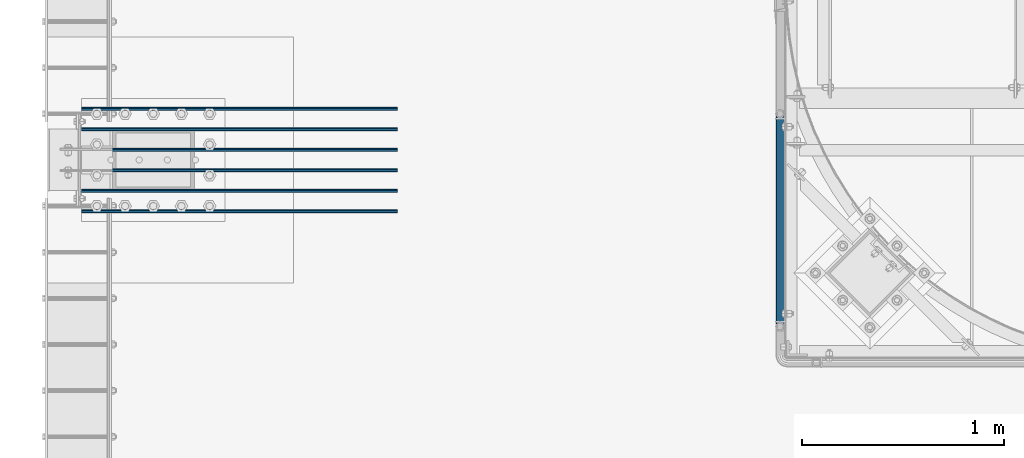
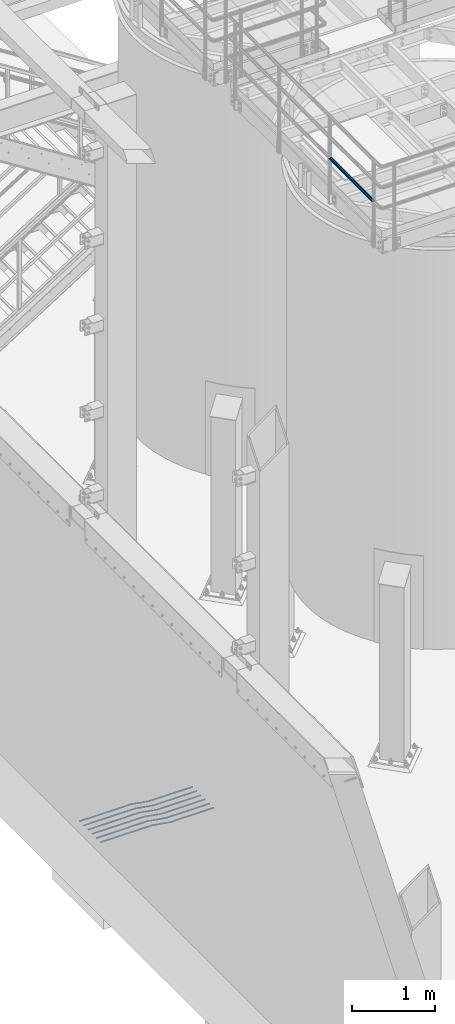
# One storey, part 913 of 1876: 7 beams, 2 elements without a shape of their own.
"""IFC2X3 building model written with IfcOpenShell, lengths in millimetres."""

from ifc_helpers import new_model, si_unit, frame, origin_with_axes, place, context, subcontext, project, spatial, faceted_brep, material, type_object, element, aggregate, save


model = new_model("IFC2X3")

# Units and contexts
model_context = context("Model", 3, precision=1e-05, world=origin_with_axes())
body_context = subcontext(model_context, "Body", "Model", "MODEL_VIEW")
ifc_project = project(units=[si_unit("LENGTHUNIT", "METRE", prefix="MILLI"), si_unit("AREAUNIT", "SQUARE_METRE"), si_unit("VOLUMEUNIT", "CUBIC_METRE"), si_unit("MASSUNIT", "GRAM", prefix="KILO"), si_unit("TIMEUNIT", "SECOND"), si_unit("PLANEANGLEUNIT", "RADIAN"), si_unit("SOLIDANGLEUNIT", "STERADIAN"), si_unit("THERMODYNAMICTEMPERATUREUNIT", "DEGREE_CELSIUS"), si_unit("LUMINOUSINTENSITYUNIT", "LUMEN")], contexts=[model_context])

# Site, building, storey
site_placement = place(None, origin_with_axes())
site = spatial("IfcSite", under=ifc_project, at=site_placement, CompositionType="ELEMENT")
building_placement = place(site_placement, origin_with_axes())
building = spatial("IfcBuilding", under=site, at=building_placement, Name="Undefined", CompositionType="ELEMENT")
storey_placement = place(building_placement, origin_with_axes())
storey = spatial("IfcBuildingStorey", under=building, at=storey_placement, Name="Undefined", CompositionType="ELEMENT", Elevation=0.0)

# Assembly, beam
assembly_1_placement = place(storey_placement, origin_with_axes())
assembly_1 = element("IfcElementAssembly", 1, at=assembly_1_placement, inside=storey, Name="HANDRAIL", AssemblyPlace="NOTDEFINED", PredefinedType="RIGID_FRAME")
ifc_material_1 = material()
beam_type_1 = type_object("IfcBeamType", Name="PIPE1-1/4STD", PredefinedType="NOTDEFINED")
beam_1_placement = place(assembly_1_placement, frame((3338.06943150122, -15252.6644042969, 8480.425), z_axis=(0.0, 0.0, 1.0), x_axis=(0.0, 1.0, 0.0)))
beam_1 = element("IfcBeam", 2, at=beam_1_placement, type_object=beam_type_1, material=ifc_material_1, Name="RAIL", ObjectType="PIPE1-1/4STD", context=body_context, shape_type="Brep", body=[
    faceted_brep([(1035.84245243742, -10.5409999999993, 18.2575475625836), (1035.84245243742, -10.5409999999993, 13.3999612267253), (1035.36603877327, -8.76300000000083, 15.1779612267255), (1033.018, 0.0, 17.5259999999998), (1033.018, 0.0, 21.0820000000003), (1035.36603877327, 8.76300000000083, 15.1779612267255), (1035.84245243742, 10.5409999999993, 13.3999612267253), (1035.84245243742, 10.5409999999993, 18.2575475625836), (1054.1, 21.0820000000003, 0.0), (1043.559, 18.2575475625836, 10.5409999999993), (1043.559, 18.2575475625836, -10.5409999999993), (1040.47941366414, 15.1779612267255, 8.76300000000083), (1042.82745243742, 17.5259999999998, 0.0), (1040.47941366414, 15.1779612267255, -8.76300000000083), (1035.84245243742, 10.5409999999993, -13.3999612267253), (1035.84245243742, 10.5409999999993, -18.2575475625836), (1035.36603877327, 8.76300000000083, -15.1779612267255), (1033.018, 0.0, -17.5259999999998), (1033.018, 0.0, -21.0820000000003), (1035.84245243742, -10.5409999999993, -13.3999612267253), (1035.84245243742, -10.5409999999993, -18.2575475625836), (1035.36603877327, -8.76300000000083, -15.1779612267255), (1054.1, -21.0820000000003, 0.0), (1043.559, -18.2575475625836, -10.5409999999993), (1043.559, -18.2575475625836, 10.5409999999993), (1040.47941366414, -15.1779612267255, -8.76300000000083), (1042.82745243742, -17.5259999999998, 0.0), (1040.47941366414, -15.1779612267255, 8.76300000000083), (10.5409999957128, -18.2575475672238, -10.5409999999993), (18.2575475625817, -10.5410000000011, -18.2575475625836), (9.09494701772928e-13, 21.0820000000003, 0.0), (10.5409999957128, 18.2575475579433, -10.5409999999993), (10.5409999999983, 18.2575475625836, 10.5410000000011), (18.2575475625817, 10.5409999999993, 18.2575475625836), (21.0819999999985, 1.81898940354586e-12, 21.0820000000003), (18.2575475625817, 10.5409999999993, -18.2575475625836), (21.0819999999985, 0.0, -21.0819999999985), (21.0819999999985, 0.0, -17.5259999999998), (18.2575475625817, -10.5409999999974, -13.3999612267271), (18.7339612267233, -8.76300000000083, -15.1779612267255), (18.7339612267251, 8.76299999999901, -15.1779612267255), (18.2575475625817, 10.5410000000011, -13.3999612267235), (13.6205863358573, 15.1779612267255, -8.76299999999901), (11.2725475625839, 17.5259999999998, 0.0), (13.6205863358573, 15.1779612267255, 8.76300000000083), (18.2575475625817, 10.5410000000011, 13.3999612267253), (18.7339612267251, 8.76299999999901, 15.1779612267273), (21.0819999999985, 1.81898940354586e-12, 17.5259999999998), (18.7339612267233, -8.76300000000083, 15.1779612267273), (18.2575475625817, -10.5409999999974, 13.3999612267289), (18.2575475625817, -10.5410000000011, 18.2575475625836), (10.5409999999983, -18.2575475625836, 10.5410000000011), (9.09494701772928e-13, -21.0820000000003, 0.0), (13.6205863358537, -15.1779612267255, 8.76300000000083), (11.2725475625793, -17.5259999999998, 0.0), (13.6205863358537, -15.1779612267255, -8.76299999999901)], [[[0, 1, 2, 3, 4]], [[4, 3, 5, 6, 7]], [[8, 9, 10]], [[7, 6, 11, 12, 13, 14, 15, 10, 9]], [[16, 17, 18, 15, 14]], [[19, 20, 18, 17, 21]], [[22, 23, 24]], [[24, 23, 20, 19, 25, 26, 27, 1, 0]], [[28, 29, 20, 23]], [[30, 31, 32]], [[33, 34, 4, 7]], [[32, 33, 7, 9]], [[30, 32, 9, 8]], [[31, 30, 8, 10]], [[35, 31, 10, 15]], [[36, 35, 15, 18]], [[29, 36, 18, 20]], [[37, 36, 29, 38, 39]], [[40, 41, 35, 36, 37]], [[32, 31, 35, 41, 42, 43, 44, 45, 33]], [[33, 45, 46, 47, 34]], [[34, 47, 48, 49, 50]], [[34, 50, 0, 4]], [[50, 51, 24, 0]], [[51, 52, 22, 24]], [[52, 28, 23, 22]], [[51, 28, 52]], [[50, 49, 53, 54, 55, 38, 29, 28, 51]], [[55, 54, 26, 25]], [[21, 39, 38, 55, 25, 19]], [[37, 39, 21, 17]], [[40, 37, 17, 16]], [[42, 41, 40, 16, 14, 13]], [[43, 42, 13, 12]], [[44, 43, 12, 11]], [[5, 46, 45, 44, 11, 6]], [[47, 46, 5, 3]], [[48, 47, 3, 2]], [[53, 49, 48, 2, 1, 27]], [[54, 53, 27, 26]]]),
])
aggregate(assembly_1, [beam_1])

# Assembly, beams
assembly_2_placement = place(storey_placement, origin_with_axes())
assembly_2 = element("IfcElementAssembly", 3, at=assembly_2_placement, inside=storey, Name="PLATE", AssemblyPlace="NOTDEFINED", PredefinedType="RIGID_FRAME")
ifc_material_2 = material(Name="STEEL/A706-GR.60")
beam_type_2 = type_object("IfcBeamType", Name="5 REBAR", PredefinedType="NOTDEFINED")
beam_2_placement = place(assembly_2_placement, frame((-123.825012207033, -14579.599983724, -58.7375000000029), z_axis=(0.0, 1.0, 0.0), x_axis=(1.0, 0.0, 0.0)))
beam_2 = element("IfcBeam", 4, at=beam_2_placement, type_object=beam_type_2, material=ifc_material_2, Name="REBAR", ObjectType="5 REBAR", context=body_context, shape_type="Brep", body=[
    faceted_brep([(0.0, -7.9375, 0.0), (0.0, -5.61266007566822, -5.61266007566883), (710.034986674476, -5.61266007566822, -5.61266007566883), (710.034986674476, -7.9375, 0.0), (0.0, 0.0, -7.9375), (710.034986674476, 0.0, -7.9375), (0.0, 5.61266007566822, -5.61266007566883), (710.034986674476, 5.61266007566822, -5.61266007566883), (0.0, 7.9375, 0.0), (710.034986674476, 7.9375, 0.0), (0.0, 5.61266007566822, 5.61266007566883), (710.034986674476, 5.61266007566822, 5.61266007566883), (0.0, 0.0, 7.9375), (710.034986674476, 0.0, 7.9375), (0.0, -5.61266007566822, 5.61266007566883), (710.034986674476, -5.61266007566822, 5.61266007566883), (711.670256270764, -5.61266007566822, -5.61266007566883), (711.865037739587, -7.9375, 0.0), (711.200012207031, 0.0, -7.9375), (710.729768143299, 5.61266007566822, -5.61266007566883), (710.534986674476, 7.9375, 0.0), (710.729768143299, 5.61266007566822, 5.61266007566883), (711.200012207031, 0.0, 7.9375), (711.670256270764, -5.61266007566822, 5.61266007566883), (713.282728188834, -5.34055537895146, -5.61266007566883), (713.669575632193, -7.63298416286913, 0.0), (712.34879584451, 0.193857281957023, -7.9375), (711.414863500185, 5.72826994286551, -5.61266007566883), (711.028016056827, 8.02069872678318, 0.0), (711.414863500185, 5.72826994286551, 5.61266007566883), (712.34879584451, 0.193857281957023, 7.9375), (713.282728188834, -5.34055537895146, 5.61266007566883), (964.985099878721, 37.1342292941951, -5.61266007566883), (965.371947322079, 34.8418005102774, 0.0), (964.051167534397, 42.6686419551035, -7.9375), (963.117235190072, 48.203054616012, -5.61266007566883), (962.730387746714, 50.4954833999297, 0.0), (963.117235190072, 48.203054616012, 5.61266007566883), (964.051167534397, 42.6686419551035, 7.9375), (964.985099878721, 37.1342292941951, 5.61266007566883), (965.670195235607, 37.2498391613923, -5.61266007566883), (965.864976704431, 34.9249992370606, 0.0), (965.199951171875, 42.8624992370605, -7.9375), (964.729707108143, 48.4751593127287, -5.61266007566883), (964.534925639319, 50.7999992370605, 0.0), (964.729707108143, 48.4751593127287, 5.61266007566883), (965.199951171875, 42.8624992370605, 7.9375), (965.670195235607, 37.2498391613923, 5.61266007566883), (966.36497670443, 37.2498391613923, -5.61266007566883), (966.36497670443, 34.9249992370605, 0.0), (966.36497670443, 42.8624992370605, -7.9375), (966.36497670443, 48.4751593127288, -5.61266007566883), (966.36497670443, 50.7999992370605, 0.0), (966.36497670443, 48.4751593127288, 5.61266007566883), (966.36497670443, 42.8624992370605, 7.9375), (966.36497670443, 37.2498391613923, 5.61266007566883), (1566.86254882812, 37.2498391613923, -5.61266007566883), (1566.86254882812, 34.9249992370605, 0.0), (1566.86254882812, 42.8624992370605, -7.9375), (1566.86254882812, 48.4751593127288, -5.61266007566883), (1566.86254882812, 50.7999992370605, 0.0), (1566.86254882812, 48.4751593127288, 5.61266007566883), (1566.86254882812, 42.8624992370605, 7.9375), (1566.86254882812, 37.2498391613923, 5.61266007566883)], [[[0, 1, 2, 3]], [[1, 4, 5, 2]], [[4, 6, 7, 5]], [[6, 8, 9, 7]], [[8, 10, 11, 9]], [[10, 12, 13, 11]], [[12, 14, 15, 13]], [[14, 0, 3, 15]], [[14, 12, 10, 8, 6, 4, 1, 0]], [[3, 2, 16, 17]], [[2, 5, 18, 16]], [[5, 7, 19, 18]], [[7, 9, 20, 19]], [[9, 11, 21, 20]], [[11, 13, 22, 21]], [[13, 15, 23, 22]], [[15, 3, 17, 23]], [[17, 16, 24, 25]], [[16, 18, 26, 24]], [[18, 19, 27, 26]], [[19, 20, 28, 27]], [[20, 21, 29, 28]], [[21, 22, 30, 29]], [[22, 23, 31, 30]], [[23, 17, 25, 31]], [[25, 24, 32, 33]], [[24, 26, 34, 32]], [[26, 27, 35, 34]], [[27, 28, 36, 35]], [[28, 29, 37, 36]], [[29, 30, 38, 37]], [[30, 31, 39, 38]], [[31, 25, 33, 39]], [[33, 32, 40, 41]], [[32, 34, 42, 40]], [[34, 35, 43, 42]], [[35, 36, 44, 43]], [[36, 37, 45, 44]], [[37, 38, 46, 45]], [[38, 39, 47, 46]], [[39, 33, 41, 47]], [[41, 40, 48, 49]], [[40, 42, 50, 48]], [[42, 43, 51, 50]], [[43, 44, 52, 51]], [[44, 45, 53, 52]], [[45, 46, 54, 53]], [[46, 47, 55, 54]], [[47, 41, 49, 55]], [[49, 48, 56, 57]], [[48, 50, 58, 56]], [[50, 51, 59, 58]], [[51, 52, 60, 59]], [[52, 53, 61, 60]], [[53, 54, 62, 61]], [[54, 55, 63, 62]], [[55, 49, 57, 63]], [[58, 59, 60, 61, 62, 63, 57, 56]]]),
])
beam_3_placement = place(assembly_2_placement, frame((-123.825012207033, -14477.999983724, -58.7375000000029), z_axis=(0.0, 1.0, 0.0), x_axis=(1.0, 0.0, 0.0)))
beam_3 = element("IfcBeam", 5, at=beam_3_placement, type_object=beam_type_2, material=ifc_material_2, Name="REBAR", ObjectType="5 REBAR", context=body_context, shape_type="Brep", body=[
    faceted_brep([(0.0, -7.9375, 0.0), (0.0, -5.61266007566822, -5.61266007566883), (710.034986674476, -5.61266007566822, -5.61266007566883), (710.034986674476, -7.9375, 0.0), (0.0, 0.0, -7.9375), (710.034986674476, 0.0, -7.9375), (0.0, 5.61266007566822, -5.61266007566883), (710.034986674476, 5.61266007566822, -5.61266007566883), (0.0, 7.9375, 0.0), (710.034986674476, 7.9375, 0.0), (0.0, 5.61266007566822, 5.61266007566883), (710.034986674476, 5.61266007566822, 5.61266007566883), (0.0, 0.0, 7.9375), (710.034986674476, 0.0, 7.9375), (0.0, -5.61266007566822, 5.61266007566883), (710.034986674476, -5.61266007566822, 5.61266007566883), (711.670256270764, -5.61266007566822, -5.61266007566883), (711.865037739587, -7.9375, 0.0), (711.200012207031, 0.0, -7.9375), (710.729768143299, 5.61266007566822, -5.61266007566883), (710.534986674476, 7.9375, 0.0), (710.729768143299, 5.61266007566822, 5.61266007566883), (711.200012207031, 0.0, 7.9375), (711.670256270764, -5.61266007566822, 5.61266007566883), (713.282728188834, -5.34055537895146, -5.61266007566883), (713.669575632193, -7.63298416286913, 0.0), (712.34879584451, 0.193857281957023, -7.9375), (711.414863500185, 5.72826994286551, -5.61266007566883), (711.028016056827, 8.02069872678318, 0.0), (711.414863500185, 5.72826994286551, 5.61266007566883), (712.34879584451, 0.193857281957023, 7.9375), (713.282728188834, -5.34055537895146, 5.61266007566883), (964.985099878721, 37.1342292941951, -5.61266007566883), (965.371947322079, 34.8418005102774, 0.0), (964.051167534397, 42.6686419551035, -7.9375), (963.117235190072, 48.203054616012, -5.61266007566883), (962.730387746714, 50.4954833999297, 0.0), (963.117235190072, 48.203054616012, 5.61266007566883), (964.051167534397, 42.6686419551035, 7.9375), (964.985099878721, 37.1342292941951, 5.61266007566883), (965.670195235607, 37.2498391613923, -5.61266007566883), (965.864976704431, 34.9249992370606, 0.0), (965.199951171875, 42.8624992370605, -7.9375), (964.729707108143, 48.4751593127287, -5.61266007566883), (964.534925639319, 50.7999992370605, 0.0), (964.729707108143, 48.4751593127287, 5.61266007566883), (965.199951171875, 42.8624992370605, 7.9375), (965.670195235607, 37.2498391613923, 5.61266007566883), (966.36497670443, 37.2498391613923, -5.61266007566883), (966.36497670443, 34.9249992370605, 0.0), (966.36497670443, 42.8624992370605, -7.9375), (966.36497670443, 48.4751593127288, -5.61266007566883), (966.36497670443, 50.7999992370605, 0.0), (966.36497670443, 48.4751593127288, 5.61266007566883), (966.36497670443, 42.8624992370605, 7.9375), (966.36497670443, 37.2498391613923, 5.61266007566883), (1566.86254882812, 37.2498391613923, -5.61266007566883), (1566.86254882812, 34.9249992370605, 0.0), (1566.86254882812, 42.8624992370605, -7.9375), (1566.86254882812, 48.4751593127288, -5.61266007566883), (1566.86254882812, 50.7999992370605, 0.0), (1566.86254882812, 48.4751593127288, 5.61266007566883), (1566.86254882812, 42.8624992370605, 7.9375), (1566.86254882812, 37.2498391613923, 5.61266007566883)], [[[0, 1, 2, 3]], [[1, 4, 5, 2]], [[4, 6, 7, 5]], [[6, 8, 9, 7]], [[8, 10, 11, 9]], [[10, 12, 13, 11]], [[12, 14, 15, 13]], [[14, 0, 3, 15]], [[14, 12, 10, 8, 6, 4, 1, 0]], [[3, 2, 16, 17]], [[2, 5, 18, 16]], [[5, 7, 19, 18]], [[7, 9, 20, 19]], [[9, 11, 21, 20]], [[11, 13, 22, 21]], [[13, 15, 23, 22]], [[15, 3, 17, 23]], [[17, 16, 24, 25]], [[16, 18, 26, 24]], [[18, 19, 27, 26]], [[19, 20, 28, 27]], [[20, 21, 29, 28]], [[21, 22, 30, 29]], [[22, 23, 31, 30]], [[23, 17, 25, 31]], [[25, 24, 32, 33]], [[24, 26, 34, 32]], [[26, 27, 35, 34]], [[27, 28, 36, 35]], [[28, 29, 37, 36]], [[29, 30, 38, 37]], [[30, 31, 39, 38]], [[31, 25, 33, 39]], [[33, 32, 40, 41]], [[32, 34, 42, 40]], [[34, 35, 43, 42]], [[35, 36, 44, 43]], [[36, 37, 45, 44]], [[37, 38, 46, 45]], [[38, 39, 47, 46]], [[39, 33, 41, 47]], [[41, 40, 48, 49]], [[40, 42, 50, 48]], [[42, 43, 51, 50]], [[43, 44, 52, 51]], [[44, 45, 53, 52]], [[45, 46, 54, 53]], [[46, 47, 55, 54]], [[47, 41, 49, 55]], [[49, 48, 56, 57]], [[48, 50, 58, 56]], [[50, 51, 59, 58]], [[51, 52, 60, 59]], [[52, 53, 61, 60]], [[53, 54, 62, 61]], [[54, 55, 63, 62]], [[55, 49, 57, 63]], [[58, 59, 60, 61, 62, 63, 57, 56]]]),
])
beam_4_placement = place(assembly_2_placement, frame((-123.825012207033, -14376.399991862, -58.7375000000029), z_axis=(0.0, 1.0, 0.0), x_axis=(1.0, 0.0, 0.0)))
beam_4 = element("IfcBeam", 6, at=beam_4_placement, type_object=beam_type_2, material=ifc_material_2, Name="REBAR", ObjectType="5 REBAR", context=body_context, shape_type="Brep", body=[
    faceted_brep([(0.0, -7.9375, 0.0), (0.0, -5.61266007566822, -5.61266007566883), (710.034986674476, -5.61266007566822, -5.61266007566883), (710.034986674476, -7.9375, 0.0), (0.0, 0.0, -7.9375), (710.034986674476, 0.0, -7.9375), (0.0, 5.61266007566822, -5.61266007566883), (710.034986674476, 5.61266007566822, -5.61266007566883), (0.0, 7.9375, 0.0), (710.034986674476, 7.9375, 0.0), (0.0, 5.61266007566822, 5.61266007566883), (710.034986674476, 5.61266007566822, 5.61266007566883), (0.0, 0.0, 7.9375), (710.034986674476, 0.0, 7.9375), (0.0, -5.61266007566822, 5.61266007566883), (710.034986674476, -5.61266007566822, 5.61266007566883), (711.670256270764, -5.61266007566822, -5.61266007566883), (711.865037739587, -7.9375, 0.0), (711.200012207031, 0.0, -7.9375), (710.729768143299, 5.61266007566822, -5.61266007566883), (710.534986674476, 7.9375, 0.0), (710.729768143299, 5.61266007566822, 5.61266007566883), (711.200012207031, 0.0, 7.9375), (711.670256270764, -5.61266007566822, 5.61266007566883), (713.282728188834, -5.34055537895146, -5.61266007566883), (713.669575632193, -7.63298416286913, 0.0), (712.34879584451, 0.193857281957023, -7.9375), (711.414863500185, 5.72826994286551, -5.61266007566883), (711.028016056827, 8.02069872678318, 0.0), (711.414863500185, 5.72826994286551, 5.61266007566883), (712.34879584451, 0.193857281957023, 7.9375), (713.282728188834, -5.34055537895146, 5.61266007566883), (964.985099878721, 37.1342292941951, -5.61266007566883), (965.371947322079, 34.8418005102774, 0.0), (964.051167534397, 42.6686419551035, -7.9375), (963.117235190072, 48.203054616012, -5.61266007566883), (962.730387746714, 50.4954833999297, 0.0), (963.117235190072, 48.203054616012, 5.61266007566883), (964.051167534397, 42.6686419551035, 7.9375), (964.985099878721, 37.1342292941951, 5.61266007566883), (965.670195235607, 37.2498391613923, -5.61266007566883), (965.864976704431, 34.9249992370606, 0.0), (965.199951171875, 42.8624992370605, -7.9375), (964.729707108143, 48.4751593127287, -5.61266007566883), (964.534925639319, 50.7999992370605, 0.0), (964.729707108143, 48.4751593127287, 5.61266007566883), (965.199951171875, 42.8624992370605, 7.9375), (965.670195235607, 37.2498391613923, 5.61266007566883), (966.36497670443, 37.2498391613923, -5.61266007566883), (966.36497670443, 34.9249992370605, 0.0), (966.36497670443, 42.8624992370605, -7.9375), (966.36497670443, 48.4751593127288, -5.61266007566883), (966.36497670443, 50.7999992370605, 0.0), (966.36497670443, 48.4751593127288, 5.61266007566883), (966.36497670443, 42.8624992370605, 7.9375), (966.36497670443, 37.2498391613923, 5.61266007566883), (1566.86254882812, 37.2498391613923, -5.61266007566883), (1566.86254882812, 34.9249992370605, 0.0), (1566.86254882812, 42.8624992370605, -7.9375), (1566.86254882812, 48.4751593127288, -5.61266007566883), (1566.86254882812, 50.7999992370605, 0.0), (1566.86254882812, 48.4751593127288, 5.61266007566883), (1566.86254882812, 42.8624992370605, 7.9375), (1566.86254882812, 37.2498391613923, 5.61266007566883)], [[[0, 1, 2, 3]], [[1, 4, 5, 2]], [[4, 6, 7, 5]], [[6, 8, 9, 7]], [[8, 10, 11, 9]], [[10, 12, 13, 11]], [[12, 14, 15, 13]], [[14, 0, 3, 15]], [[14, 12, 10, 8, 6, 4, 1, 0]], [[3, 2, 16, 17]], [[2, 5, 18, 16]], [[5, 7, 19, 18]], [[7, 9, 20, 19]], [[9, 11, 21, 20]], [[11, 13, 22, 21]], [[13, 15, 23, 22]], [[15, 3, 17, 23]], [[17, 16, 24, 25]], [[16, 18, 26, 24]], [[18, 19, 27, 26]], [[19, 20, 28, 27]], [[20, 21, 29, 28]], [[21, 22, 30, 29]], [[22, 23, 31, 30]], [[23, 17, 25, 31]], [[25, 24, 32, 33]], [[24, 26, 34, 32]], [[26, 27, 35, 34]], [[27, 28, 36, 35]], [[28, 29, 37, 36]], [[29, 30, 38, 37]], [[30, 31, 39, 38]], [[31, 25, 33, 39]], [[33, 32, 40, 41]], [[32, 34, 42, 40]], [[34, 35, 43, 42]], [[35, 36, 44, 43]], [[36, 37, 45, 44]], [[37, 38, 46, 45]], [[38, 39, 47, 46]], [[39, 33, 41, 47]], [[41, 40, 48, 49]], [[40, 42, 50, 48]], [[42, 43, 51, 50]], [[43, 44, 52, 51]], [[44, 45, 53, 52]], [[45, 46, 54, 53]], [[46, 47, 55, 54]], [[47, 41, 49, 55]], [[49, 48, 56, 57]], [[48, 50, 58, 56]], [[50, 51, 59, 58]], [[51, 52, 60, 59]], [[52, 53, 61, 60]], [[53, 54, 62, 61]], [[54, 55, 63, 62]], [[55, 49, 57, 63]], [[58, 59, 60, 61, 62, 63, 57, 56]]]),
])
beam_5_placement = place(assembly_2_placement, frame((-123.825012207033, -14274.799991862, -58.7375000000029), z_axis=(0.0, 1.0, 0.0), x_axis=(1.0, 0.0, 0.0)))
beam_5 = element("IfcBeam", 7, at=beam_5_placement, type_object=beam_type_2, material=ifc_material_2, Name="REBAR", ObjectType="5 REBAR", context=body_context, shape_type="Brep", body=[
    faceted_brep([(0.0, -7.9375, 0.0), (0.0, -5.61266007566822, -5.61266007566883), (710.034986674476, -5.61266007566822, -5.61266007566883), (710.034986674476, -7.9375, 0.0), (0.0, 0.0, -7.9375), (710.034986674476, 0.0, -7.9375), (0.0, 5.61266007566822, -5.61266007566883), (710.034986674476, 5.61266007566822, -5.61266007566883), (0.0, 7.9375, 0.0), (710.034986674476, 7.9375, 0.0), (0.0, 5.61266007566822, 5.61266007566883), (710.034986674476, 5.61266007566822, 5.61266007566883), (0.0, 0.0, 7.9375), (710.034986674476, 0.0, 7.9375), (0.0, -5.61266007566822, 5.61266007566883), (710.034986674476, -5.61266007566822, 5.61266007566883), (711.670256270764, -5.61266007566822, -5.61266007566883), (711.865037739587, -7.9375, 0.0), (711.200012207031, 0.0, -7.9375), (710.729768143299, 5.61266007566822, -5.61266007566883), (710.534986674476, 7.9375, 0.0), (710.729768143299, 5.61266007566822, 5.61266007566883), (711.200012207031, 0.0, 7.9375), (711.670256270764, -5.61266007566822, 5.61266007566883), (713.282728188834, -5.34055537895146, -5.61266007566883), (713.669575632193, -7.63298416286913, 0.0), (712.34879584451, 0.193857281957023, -7.9375), (711.414863500185, 5.72826994286551, -5.61266007566883), (711.028016056827, 8.02069872678318, 0.0), (711.414863500185, 5.72826994286551, 5.61266007566883), (712.34879584451, 0.193857281957023, 7.9375), (713.282728188834, -5.34055537895146, 5.61266007566883), (964.985099878721, 37.1342292941951, -5.61266007566883), (965.371947322079, 34.8418005102774, 0.0), (964.051167534397, 42.6686419551035, -7.9375), (963.117235190072, 48.203054616012, -5.61266007566883), (962.730387746714, 50.4954833999297, 0.0), (963.117235190072, 48.203054616012, 5.61266007566883), (964.051167534397, 42.6686419551035, 7.9375), (964.985099878721, 37.1342292941951, 5.61266007566883), (965.670195235607, 37.2498391613923, -5.61266007566883), (965.864976704431, 34.9249992370606, 0.0), (965.199951171875, 42.8624992370605, -7.9375), (964.729707108143, 48.4751593127287, -5.61266007566883), (964.534925639319, 50.7999992370605, 0.0), (964.729707108143, 48.4751593127287, 5.61266007566883), (965.199951171875, 42.8624992370605, 7.9375), (965.670195235607, 37.2498391613923, 5.61266007566883), (966.36497670443, 37.2498391613923, -5.61266007566883), (966.36497670443, 34.9249992370605, 0.0), (966.36497670443, 42.8624992370605, -7.9375), (966.36497670443, 48.4751593127288, -5.61266007566883), (966.36497670443, 50.7999992370605, 0.0), (966.36497670443, 48.4751593127288, 5.61266007566883), (966.36497670443, 42.8624992370605, 7.9375), (966.36497670443, 37.2498391613923, 5.61266007566883), (1566.86254882812, 37.2498391613923, -5.61266007566883), (1566.86254882812, 34.9249992370605, 0.0), (1566.86254882812, 42.8624992370605, -7.9375), (1566.86254882812, 48.4751593127288, -5.61266007566883), (1566.86254882812, 50.7999992370605, 0.0), (1566.86254882812, 48.4751593127288, 5.61266007566883), (1566.86254882812, 42.8624992370605, 7.9375), (1566.86254882812, 37.2498391613923, 5.61266007566883)], [[[0, 1, 2, 3]], [[1, 4, 5, 2]], [[4, 6, 7, 5]], [[6, 8, 9, 7]], [[8, 10, 11, 9]], [[10, 12, 13, 11]], [[12, 14, 15, 13]], [[14, 0, 3, 15]], [[14, 12, 10, 8, 6, 4, 1, 0]], [[3, 2, 16, 17]], [[2, 5, 18, 16]], [[5, 7, 19, 18]], [[7, 9, 20, 19]], [[9, 11, 21, 20]], [[11, 13, 22, 21]], [[13, 15, 23, 22]], [[15, 3, 17, 23]], [[17, 16, 24, 25]], [[16, 18, 26, 24]], [[18, 19, 27, 26]], [[19, 20, 28, 27]], [[20, 21, 29, 28]], [[21, 22, 30, 29]], [[22, 23, 31, 30]], [[23, 17, 25, 31]], [[25, 24, 32, 33]], [[24, 26, 34, 32]], [[26, 27, 35, 34]], [[27, 28, 36, 35]], [[28, 29, 37, 36]], [[29, 30, 38, 37]], [[30, 31, 39, 38]], [[31, 25, 33, 39]], [[33, 32, 40, 41]], [[32, 34, 42, 40]], [[34, 35, 43, 42]], [[35, 36, 44, 43]], [[36, 37, 45, 44]], [[37, 38, 46, 45]], [[38, 39, 47, 46]], [[39, 33, 41, 47]], [[41, 40, 48, 49]], [[40, 42, 50, 48]], [[42, 43, 51, 50]], [[43, 44, 52, 51]], [[44, 45, 53, 52]], [[45, 46, 54, 53]], [[46, 47, 55, 54]], [[47, 41, 49, 55]], [[49, 48, 56, 57]], [[48, 50, 58, 56]], [[50, 51, 59, 58]], [[51, 52, 60, 59]], [[52, 53, 61, 60]], [[53, 54, 62, 61]], [[54, 55, 63, 62]], [[55, 49, 57, 63]], [[58, 59, 60, 61, 62, 63, 57, 56]]]),
])
beam_6_placement = place(assembly_2_placement, frame((-123.825012207033, -14681.199983724, -58.7375000000029), z_axis=(0.0, 1.0, 0.0), x_axis=(1.0, 0.0, 0.0)))
beam_6 = element("IfcBeam", 8, at=beam_6_placement, type_object=beam_type_2, material=ifc_material_2, Name="REBAR", ObjectType="5 REBAR", context=body_context, shape_type="Brep", body=[
    faceted_brep([(0.0, -7.9375, 0.0), (0.0, -5.61266007566822, -5.61266007566883), (710.034986674476, -5.61266007566822, -5.61266007566883), (710.034986674476, -7.9375, 0.0), (0.0, 0.0, -7.9375), (710.034986674476, 0.0, -7.9375), (0.0, 5.61266007566822, -5.61266007566883), (710.034986674476, 5.61266007566822, -5.61266007566883), (0.0, 7.9375, 0.0), (710.034986674476, 7.9375, 0.0), (0.0, 5.61266007566822, 5.61266007566883), (710.034986674476, 5.61266007566822, 5.61266007566883), (0.0, 0.0, 7.9375), (710.034986674476, 0.0, 7.9375), (0.0, -5.61266007566822, 5.61266007566883), (710.034986674476, -5.61266007566822, 5.61266007566883), (711.670256270764, -5.61266007566822, -5.61266007566883), (711.865037739587, -7.9375, 0.0), (711.200012207031, 0.0, -7.9375), (710.729768143299, 5.61266007566822, -5.61266007566883), (710.534986674476, 7.9375, 0.0), (710.729768143299, 5.61266007566822, 5.61266007566883), (711.200012207031, 0.0, 7.9375), (711.670256270764, -5.61266007566822, 5.61266007566883), (713.282728188834, -5.34055537895146, -5.61266007566883), (713.669575632193, -7.63298416286913, 0.0), (712.34879584451, 0.193857281957023, -7.9375), (711.414863500185, 5.72826994286551, -5.61266007566883), (711.028016056827, 8.02069872678318, 0.0), (711.414863500185, 5.72826994286551, 5.61266007566883), (712.34879584451, 0.193857281957023, 7.9375), (713.282728188834, -5.34055537895146, 5.61266007566883), (964.985099878721, 37.1342292941951, -5.61266007566883), (965.371947322079, 34.8418005102774, 0.0), (964.051167534397, 42.6686419551035, -7.9375), (963.117235190072, 48.203054616012, -5.61266007566883), (962.730387746714, 50.4954833999297, 0.0), (963.117235190072, 48.203054616012, 5.61266007566883), (964.051167534397, 42.6686419551035, 7.9375), (964.985099878721, 37.1342292941951, 5.61266007566883), (965.670195235607, 37.2498391613923, -5.61266007566883), (965.864976704431, 34.9249992370606, 0.0), (965.199951171875, 42.8624992370605, -7.9375), (964.729707108143, 48.4751593127287, -5.61266007566883), (964.534925639319, 50.7999992370605, 0.0), (964.729707108143, 48.4751593127287, 5.61266007566883), (965.199951171875, 42.8624992370605, 7.9375), (965.670195235607, 37.2498391613923, 5.61266007566883), (966.36497670443, 37.2498391613923, -5.61266007566883), (966.36497670443, 34.9249992370605, 0.0), (966.36497670443, 42.8624992370605, -7.9375), (966.36497670443, 48.4751593127288, -5.61266007566883), (966.36497670443, 50.7999992370605, 0.0), (966.36497670443, 48.4751593127288, 5.61266007566883), (966.36497670443, 42.8624992370605, 7.9375), (966.36497670443, 37.2498391613923, 5.61266007566883), (1566.86254882812, 37.2498391613923, -5.61266007566883), (1566.86254882812, 34.9249992370605, 0.0), (1566.86254882812, 42.8624992370605, -7.9375), (1566.86254882812, 48.4751593127288, -5.61266007566883), (1566.86254882812, 50.7999992370605, 0.0), (1566.86254882812, 48.4751593127288, 5.61266007566883), (1566.86254882812, 42.8624992370605, 7.9375), (1566.86254882812, 37.2498391613923, 5.61266007566883)], [[[0, 1, 2, 3]], [[1, 4, 5, 2]], [[4, 6, 7, 5]], [[6, 8, 9, 7]], [[8, 10, 11, 9]], [[10, 12, 13, 11]], [[12, 14, 15, 13]], [[14, 0, 3, 15]], [[14, 12, 10, 8, 6, 4, 1, 0]], [[3, 2, 16, 17]], [[2, 5, 18, 16]], [[5, 7, 19, 18]], [[7, 9, 20, 19]], [[9, 11, 21, 20]], [[11, 13, 22, 21]], [[13, 15, 23, 22]], [[15, 3, 17, 23]], [[17, 16, 24, 25]], [[16, 18, 26, 24]], [[18, 19, 27, 26]], [[19, 20, 28, 27]], [[20, 21, 29, 28]], [[21, 22, 30, 29]], [[22, 23, 31, 30]], [[23, 17, 25, 31]], [[25, 24, 32, 33]], [[24, 26, 34, 32]], [[26, 27, 35, 34]], [[27, 28, 36, 35]], [[28, 29, 37, 36]], [[29, 30, 38, 37]], [[30, 31, 39, 38]], [[31, 25, 33, 39]], [[33, 32, 40, 41]], [[32, 34, 42, 40]], [[34, 35, 43, 42]], [[35, 36, 44, 43]], [[36, 37, 45, 44]], [[37, 38, 46, 45]], [[38, 39, 47, 46]], [[39, 33, 41, 47]], [[41, 40, 48, 49]], [[40, 42, 50, 48]], [[42, 43, 51, 50]], [[43, 44, 52, 51]], [[44, 45, 53, 52]], [[45, 46, 54, 53]], [[46, 47, 55, 54]], [[47, 41, 49, 55]], [[49, 48, 56, 57]], [[48, 50, 58, 56]], [[50, 51, 59, 58]], [[51, 52, 60, 59]], [[52, 53, 61, 60]], [[53, 54, 62, 61]], [[54, 55, 63, 62]], [[55, 49, 57, 63]], [[58, 59, 60, 61, 62, 63, 57, 56]]]),
])
beam_7_placement = place(assembly_2_placement, frame((-123.825012207033, -14173.2, -58.7374999999993), z_axis=(0.0, 1.0, 0.0), x_axis=(1.0, 0.0, 0.0)))
beam_7 = element("IfcBeam", 9, at=beam_7_placement, type_object=beam_type_2, material=ifc_material_2, Name="REBAR", ObjectType="5 REBAR", context=body_context, shape_type="Brep", body=[
    faceted_brep([(0.0, -7.9375, 0.0), (0.0, -5.61266007566822, -5.61266007566883), (710.034986674476, -5.61266007566822, -5.61266007566883), (710.034986674476, -7.9375, 0.0), (0.0, 0.0, -7.9375), (710.034986674476, 0.0, -7.9375), (0.0, 5.61266007566822, -5.61266007566883), (710.034986674476, 5.61266007566822, -5.61266007566883), (0.0, 7.9375, 0.0), (710.034986674476, 7.9375, 0.0), (0.0, 5.61266007566822, 5.61266007566883), (710.034986674476, 5.61266007566822, 5.61266007566883), (0.0, 0.0, 7.9375), (710.034986674476, 0.0, 7.9375), (0.0, -5.61266007566822, 5.61266007566883), (710.034986674476, -5.61266007566822, 5.61266007566883), (711.670256270764, -5.61266007566822, -5.61266007566883), (711.865037739587, -7.9375, 0.0), (711.200012207031, 0.0, -7.9375), (710.729768143299, 5.61266007566822, -5.61266007566883), (710.534986674476, 7.9375, 0.0), (710.729768143299, 5.61266007566822, 5.61266007566883), (711.200012207031, 0.0, 7.9375), (711.670256270764, -5.61266007566822, 5.61266007566883), (713.282728188834, -5.34055537895146, -5.61266007566883), (713.669575632193, -7.63298416286913, 0.0), (712.34879584451, 0.193857281957023, -7.9375), (711.414863500185, 5.72826994286551, -5.61266007566883), (711.028016056827, 8.02069872678318, 0.0), (711.414863500185, 5.72826994286551, 5.61266007566883), (712.34879584451, 0.193857281957023, 7.9375), (713.282728188834, -5.34055537895146, 5.61266007566883), (964.985099878721, 37.1342292941951, -5.61266007566883), (965.371947322079, 34.8418005102774, 0.0), (964.051167534397, 42.6686419551035, -7.9375), (963.117235190072, 48.203054616012, -5.61266007566883), (962.730387746714, 50.4954833999297, 0.0), (963.117235190072, 48.203054616012, 5.61266007566883), (964.051167534397, 42.6686419551035, 7.9375), (964.985099878721, 37.1342292941951, 5.61266007566883), (965.670195235607, 37.2498391613923, -5.61266007566883), (965.864976704431, 34.9249992370606, 0.0), (965.199951171875, 42.8624992370605, -7.9375), (964.729707108143, 48.4751593127287, -5.61266007566883), (964.534925639319, 50.7999992370605, 0.0), (964.729707108143, 48.4751593127287, 5.61266007566883), (965.199951171875, 42.8624992370605, 7.9375), (965.670195235607, 37.2498391613923, 5.61266007566883), (966.36497670443, 37.2498391613923, -5.61266007566883), (966.36497670443, 34.9249992370605, 0.0), (966.36497670443, 42.8624992370605, -7.9375), (966.36497670443, 48.4751593127288, -5.61266007566883), (966.36497670443, 50.7999992370605, 0.0), (966.36497670443, 48.4751593127288, 5.61266007566883), (966.36497670443, 42.8624992370605, 7.9375), (966.36497670443, 37.2498391613923, 5.61266007566883), (1566.86254882812, 37.2498391613923, -5.61266007566883), (1566.86254882812, 34.9249992370605, 0.0), (1566.86254882812, 42.8624992370605, -7.9375), (1566.86254882812, 48.4751593127288, -5.61266007566883), (1566.86254882812, 50.7999992370605, 0.0), (1566.86254882812, 48.4751593127288, 5.61266007566883), (1566.86254882812, 42.8624992370605, 7.9375), (1566.86254882812, 37.2498391613923, 5.61266007566883)], [[[0, 1, 2, 3]], [[1, 4, 5, 2]], [[4, 6, 7, 5]], [[6, 8, 9, 7]], [[8, 10, 11, 9]], [[10, 12, 13, 11]], [[12, 14, 15, 13]], [[14, 0, 3, 15]], [[14, 12, 10, 8, 6, 4, 1, 0]], [[3, 2, 16, 17]], [[2, 5, 18, 16]], [[5, 7, 19, 18]], [[7, 9, 20, 19]], [[9, 11, 21, 20]], [[11, 13, 22, 21]], [[13, 15, 23, 22]], [[15, 3, 17, 23]], [[17, 16, 24, 25]], [[16, 18, 26, 24]], [[18, 19, 27, 26]], [[19, 20, 28, 27]], [[20, 21, 29, 28]], [[21, 22, 30, 29]], [[22, 23, 31, 30]], [[23, 17, 25, 31]], [[25, 24, 32, 33]], [[24, 26, 34, 32]], [[26, 27, 35, 34]], [[27, 28, 36, 35]], [[28, 29, 37, 36]], [[29, 30, 38, 37]], [[30, 31, 39, 38]], [[31, 25, 33, 39]], [[33, 32, 40, 41]], [[32, 34, 42, 40]], [[34, 35, 43, 42]], [[35, 36, 44, 43]], [[36, 37, 45, 44]], [[37, 38, 46, 45]], [[38, 39, 47, 46]], [[39, 33, 41, 47]], [[41, 40, 48, 49]], [[40, 42, 50, 48]], [[42, 43, 51, 50]], [[43, 44, 52, 51]], [[44, 45, 53, 52]], [[45, 46, 54, 53]], [[46, 47, 55, 54]], [[47, 41, 49, 55]], [[49, 48, 56, 57]], [[48, 50, 58, 56]], [[50, 51, 59, 58]], [[51, 52, 60, 59]], [[52, 53, 61, 60]], [[53, 54, 62, 61]], [[54, 55, 63, 62]], [[55, 49, 57, 63]], [[58, 59, 60, 61, 62, 63, 57, 56]]]),
])
aggregate(assembly_2, [beam_2, beam_3, beam_4, beam_5, beam_6, beam_7])

save(model, "model.ifc")
